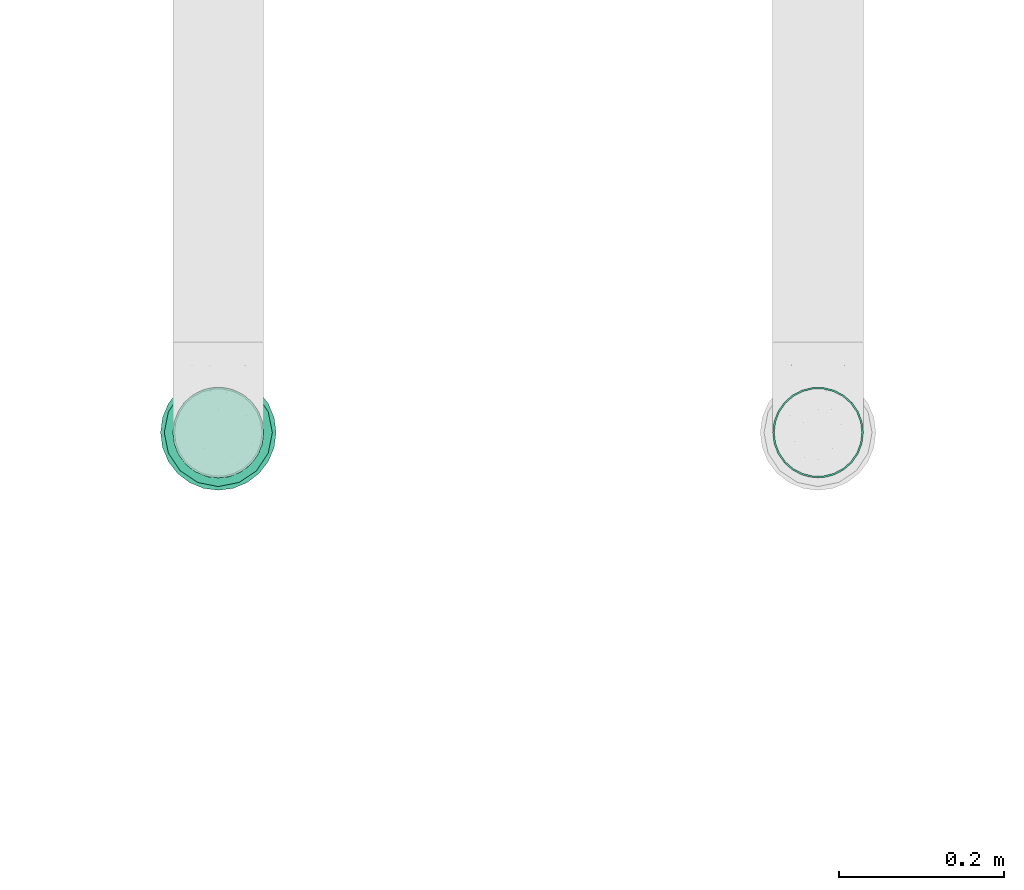
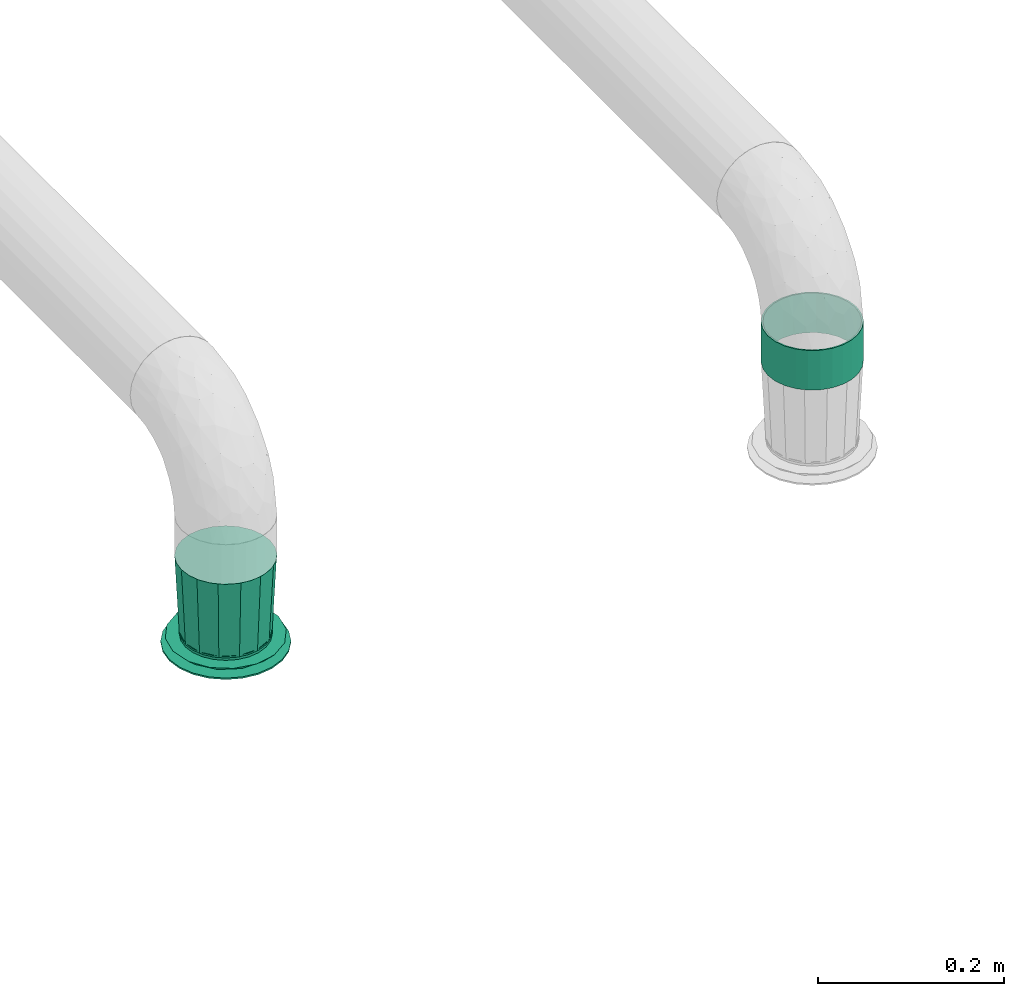
# One storey, part 93 of 115: 1 flow fitting, 1 flow segment, 1 flow terminal.
"""IFC2X3 building model written with IfcOpenShell, lengths in millimetres."""

from ifc_helpers import new_model, entity, si_unit, converted_unit, derived_unit, direction, frame, origin_with_axes, origin_2d_with_axis, place, context, subcontext, project, spatial, hollow_circle, extrude, open_shell, surface_model, source, transform, mapped, material, layer, layer_set, layer_usage, type_object, element, save


model = new_model("IFC2X3")

# Units and contexts
model_context = context("Model", 3, precision=1e-05, world=origin_with_axes(), true_north=direction((0.0, 1.0)))
body_context = subcontext(model_context, "Body", "Model", "MODEL_VIEW")
ifc_project = project(units=[si_unit("AREAUNIT", "SQUARE_METRE"), si_unit("VOLUMEUNIT", "CUBIC_METRE", prefix="DECI"), si_unit("TIMEUNIT", "SECOND"), si_unit("THERMODYNAMICTEMPERATUREUNIT", "DEGREE_CELSIUS"), si_unit("PRESSUREUNIT", "PASCAL"), si_unit("MASSUNIT", "GRAM", prefix="KILO"), si_unit("LENGTHUNIT", "METRE", prefix="MILLI"), si_unit("POWERUNIT", "WATT"), si_unit("ELECTRICCURRENTUNIT", "AMPERE"), si_unit("ELECTRICVOLTAGEUNIT", "VOLT"), derived_unit("VOLUMETRICFLOWRATEUNIT", [(si_unit("VOLUMEUNIT", "CUBIC_METRE", prefix="DECI"), 1), (si_unit("TIMEUNIT", "SECOND"), -1)]), derived_unit("LINEARVELOCITYUNIT", [(si_unit("LENGTHUNIT", "METRE"), 1), (si_unit("TIMEUNIT", "SECOND"), -1)]), derived_unit("MASSDENSITYUNIT", [(si_unit("MASSUNIT", "GRAM", prefix="KILO"), 1), (si_unit("VOLUMEUNIT", "CUBIC_METRE"), -1)]), converted_unit("PLANEANGLEUNIT", "DEGREE", entity("IfcRatioMeasure", 0.01745), si_unit("PLANEANGLEUNIT", "RADIAN"), dimensions=[0, 0, 0, 0, 0, 0, 0])], contexts=[model_context])

# Site, building, storey
site_placement = place(None, origin_with_axes())
site = spatial("IfcSite", under=ifc_project, at=site_placement, CompositionType="ELEMENT")
building_placement = place(site_placement, origin_with_axes())
building = spatial("IfcBuilding", under=site, at=building_placement, Name="mc-building", CompositionType="ELEMENT")
storey_placement = place(building_placement, frame((0.0, 0.0, 2950.0), z_axis=(0.0, 0.0, 1.0), x_axis=(1.0, 0.0, 0.0)))
storey = spatial("IfcBuildingStorey", under=building, at=storey_placement, Name="2. Korrus", CompositionType="ELEMENT", Elevation=2950.0)

# Flow terminal
air_terminal_type = type_object("IfcAirTerminalType", Name="100", PredefinedType="NOTDEFINED")
shared_shape_1 = source(origin_with_axes(), body_context, "Body", "SurfaceModel", [
    surface_model("IfcShellBasedSurfaceModel", [(11.2, 18.11733, -67.61481), (11.2, -18.11733, -67.61481), (11.2, 0.0, -70.0), (11.2, 67.61481, -18.11733), (11.2, 35.0, -60.62178), (11.2, 49.49747, -49.49747), (11.2, 60.62178, -35.0), (11.2, -67.61481, 18.11733), (11.2, -49.49747, -49.49747), (11.2, -67.61481, -18.11733), (11.2, -35.0, -60.62178), (11.2, -60.62178, -35.0), (11.2, -70.0, 0.0), (11.2, 18.11733, 67.61481), (11.2, 70.0, 0.0), (11.2, 67.61481, 18.11733), (11.2, 49.49747, 49.49747), (11.2, 60.62178, 35.0), (11.2, 35.0, 60.62178), (11.2, -49.49747, 49.49747), (11.2, -60.62178, 35.0), (11.2, -35.0, 60.62178), (11.2, -18.11733, 67.61481), (11.2, 0.0, 70.0), (9.2, 18.11733, 67.61481), (9.2, -67.61481, 18.11733), (9.2, 0.0, 70.0), (9.2, 49.49747, 49.49747), (9.2, 35.0, 60.62178), (9.2, 60.62178, 35.0), (9.2, 67.61481, 18.11733), (9.2, -35.0, 60.62178), (9.2, -49.49747, 49.49747), (9.2, -18.11733, 67.61481), (9.2, -60.62178, 35.0), (9.2, -67.61481, -18.11733), (9.2, -70.0, 0.0), (9.2, 67.61481, -18.11733), (9.2, 18.11733, -67.61481), (9.2, 49.49747, -49.49747), (9.2, 60.62178, -35.0), (9.2, 35.0, -60.62178), (9.2, -18.11733, -67.61481), (9.2, -49.49747, -49.49747), (9.2, -60.62178, -35.0), (9.2, -35.0, -60.62178), (9.2, 0.0, -70.0), (9.2, 70.0, 0.0), (9.2, 32.75, 0.0), (9.2, -16.375, 28.36233), (9.2, -28.36233, 16.375), (9.2, 16.375, 28.36233), (9.2, 0.0, 32.75), (9.2, 28.36233, 16.375), (9.2, -32.75, 0.0), (9.2, -16.375, -28.36233), (9.2, 16.375, -28.36233), (9.2, 0.0, -32.75), (9.2, 28.36233, -16.375), (9.2, -28.36233, -16.375), (6.2, -21.19625, -15.39997), (6.2, -21.19625, 15.39997), (6.2, 8.09625, 24.91768), (6.2, -8.09625, 24.91768), (6.2, -26.2, 0.0), (6.2, 21.19625, 15.39997), (6.2, -8.09625, -24.91768), (6.2, 21.19625, -15.39997), (6.2, 8.09625, -24.91768), (6.2, 26.2, 0.0), (9.2, 31.06579, -6.28555), (6.2, 23.69812, -7.69999), (6.2, -14.64625, -20.15883), (9.2, -22.36867, -22.36867), (6.2, -23.69812, -7.69999), (9.2, -31.06579, -6.28555), (6.2, 14.64625, -20.15883), (9.2, 8.1875, -30.55617), (6.2, 0.0, -24.91768), (9.2, 22.36867, -22.36867), (9.2, -8.1875, -30.55617), (9.2, -31.06579, 6.28555), (6.2, -23.69812, 7.69999), (6.2, 14.64625, 20.15883), (9.2, 22.36867, 22.36867), (6.2, 23.69812, 7.69999), (9.2, 31.06579, 6.28555), (6.2, -14.64625, 20.15883), (9.2, -8.1875, 30.55617), (6.2, 0.0, 24.91768), (9.2, -22.36867, 22.36867), (9.2, 8.1875, 30.55617), (6.2, -13.11761, 57.472), (6.2, -36.75472, 46.08897), (6.2, -53.11211, 25.57744), (6.2, 36.75472, 46.08897), (6.2, -58.95, 0.0), (6.2, 13.11761, 57.472), (6.2, 53.11211, 25.57744), (6.2, -53.11211, -25.57744), (6.2, -36.75472, -46.08897), (6.2, -13.11761, -57.472), (6.2, 58.95, 0.0), (6.2, 53.11211, -25.57744), (6.2, 13.11761, -57.472), (6.2, 36.75472, -46.08897), (0.0, -60.51411, 25.06576), (0.0, 0.0, 65.5), (0.0, 25.06576, 60.51411), (0.0, 46.3155, 46.3155), (0.0, 60.51411, 25.06576), (0.0, -46.3155, 46.3155), (0.0, -25.06576, 60.51411), (0.0, 0.0, -65.5), (0.0, -65.5, 0.0), (0.0, 65.5, 0.0), (0.0, 60.51411, -25.06576), (0.0, 46.3155, -46.3155), (0.0, 25.06576, -60.51411), (0.0, -46.3155, -46.3155), (0.0, -60.51411, -25.06576), (0.0, -25.06576, -60.51411), (6.2, 56.03105, -12.78872), (0.0, 53.4148, -35.69063), (0.0, 35.69063, -53.4148), (6.2, 24.93616, -51.78048), (0.0, -12.53288, -63.00706), (6.2, 0.0, -57.472), (0.0, -35.69063, -53.4148), (0.0, 63.00706, -12.53288), (6.2, 44.93342, -35.83321), (6.2, -24.93616, -51.78048), (6.2, -44.93342, -35.83321), (0.0, -53.4148, -35.69063), (0.0, 12.53288, -63.00706), (6.2, -56.03105, -12.78872), (0.0, -63.00706, -12.53288), (6.2, -56.03105, 12.78872), (0.0, -53.4148, 35.69063), (0.0, -35.69063, 53.4148), (6.2, -24.93616, 51.78048), (0.0, 12.53288, 63.00706), (6.2, 0.0, 57.472), (0.0, 35.69063, 53.4148), (0.0, -63.00706, 12.53288), (6.2, -44.93342, 35.83321), (6.2, 24.93616, 51.78048), (6.2, 44.93342, 35.83321), (0.0, 53.4148, 35.69063), (0.0, -12.53288, 63.00706), (6.2, 56.03105, 12.78872), (0.0, 63.00706, 12.53288), (-3.1, 12.94095, 48.29629), (-3.1, -35.35534, 35.35534), (-3.1, 0.0, 50.0), (-3.1, 35.35534, 35.35534), (-3.1, 25.0, 43.30127), (-3.1, -43.30127, 25.0), (-3.1, 43.30127, 25.0), (-3.1, -48.29629, -12.94095), (-3.1, -12.94095, 48.29629), (-3.1, -25.0, 43.30127), (-3.1, -50.0, 0.0), (-3.1, -48.29629, 12.94095), (-3.1, 48.29629, 12.94095), (-3.1, 12.94095, -48.29629), (-3.1, 50.0, 0.0), (-3.1, 48.29629, -12.94095), (-3.1, 35.35534, -35.35534), (-3.1, 43.30127, -25.0), (-3.1, 25.0, -43.30127), (-3.1, 0.0, -50.0), (-3.1, -35.35534, -35.35534), (-3.1, -43.30127, -25.0), (-3.1, -25.0, -43.30127), (-3.1, -12.94095, -48.29629), (0.0, 25.0, -43.30127), (0.0, 0.0, -50.0), (0.0, 12.94095, -48.29629), (0.0, 48.29629, -12.94095), (0.0, 35.35534, -35.35534), (0.0, -25.0, -43.30127), (0.0, 43.30127, -25.0), (0.0, -50.0, 0.0), (0.0, -12.94095, -48.29629), (0.0, -35.35534, -35.35534), (0.0, -48.29629, -12.94095), (0.0, -43.30127, -25.0), (0.0, 50.0, 0.0), (0.0, 43.30127, 25.0), (0.0, 12.94095, 48.29629), (0.0, 35.35534, 35.35534), (0.0, 25.0, 43.30127), (0.0, 0.0, 50.0), (0.0, -35.35534, 35.35534), (0.0, -43.30127, 25.0), (0.0, -48.29629, 12.94095), (0.0, -12.94095, 48.29629), (0.0, -25.0, 43.30127), (0.0, 48.29629, 12.94095), (-43.1, 0.0, 45.0), (-43.1, 11.64686, 43.46666), (-43.1, 22.5, 38.97115), (-43.1, -11.64686, 43.46666), (-43.1, 38.97115, 22.5), (-43.1, 43.46666, 11.64686), (-43.1, 31.81981, 31.81981), (-43.1, -22.5, 38.97115), (-43.1, -43.46666, 11.64686), (-43.1, -31.81981, 31.81981), (-43.1, -38.97115, 22.5), (-43.1, -45.0, 0.0), (-43.1, -43.46666, -11.64686), (-43.1, 45.0, 0.0), (-43.1, 43.46666, -11.64686), (-43.1, 38.97115, -22.5), (-43.1, 31.81981, -31.81981), (-43.1, 22.5, -38.97115), (-43.1, 11.64686, -43.46666), (-43.1, -31.81981, -31.81981), (-43.1, -38.97115, -22.5), (-43.1, -22.5, -38.97115), (-43.1, 0.0, -45.0), (-43.1, -11.64686, -43.46666), (-3.1, 22.5, -38.97115), (-3.1, 0.0, -45.0), (-3.1, 11.64686, -43.46666), (-3.1, 31.81981, -31.81981), (-3.1, -22.5, -38.97115), (-3.1, 38.97115, -22.5), (-3.1, 43.46666, -11.64686), (-3.1, 45.0, 0.0), (-3.1, -45.0, 0.0), (-3.1, -11.64686, -43.46666), (-3.1, -31.81981, -31.81981), (-3.1, -43.46666, -11.64686), (-3.1, -38.97115, -22.5), (-3.1, 0.0, 45.0), (-3.1, 43.46666, 11.64686), (-3.1, 38.97115, 22.5), (-3.1, 22.5, 38.97115), (-3.1, 31.81981, 31.81981), (-3.1, 11.64686, 43.46666), (-3.1, -11.64686, 43.46666), (-3.1, -43.46666, 11.64686), (-3.1, -31.81981, 31.81981), (-3.1, -38.97115, 22.5), (-3.1, -22.5, 38.97115)], [open_shell([[[0, 1, 2]], [[3, 0, 4]], [[5, 6, 3]], [[5, 3, 4]], [[7, 1, 0]], [[8, 7, 9]], [[10, 7, 8]], [[8, 9, 11]], [[12, 9, 7]], [[1, 7, 10]], [[7, 0, 3]], [[13, 14, 15]], [[16, 15, 17]], [[16, 18, 13]], [[16, 13, 15]], [[14, 13, 7]], [[7, 19, 20]], [[19, 7, 21]], [[7, 22, 21]], [[22, 7, 23]], [[7, 13, 23]], [[14, 7, 3]], [[24, 25, 26]], [[27, 24, 28]], [[27, 29, 30]], [[27, 30, 24]], [[25, 24, 30]], [[31, 25, 32]], [[25, 31, 33]], [[32, 25, 34]], [[33, 26, 25]], [[25, 35, 36]], [[25, 30, 37]], [[25, 37, 38]], [[39, 37, 40]], [[39, 41, 38]], [[39, 38, 37]], [[38, 42, 25]], [[35, 43, 44]], [[35, 25, 43]], [[45, 43, 25]], [[42, 45, 25]], [[38, 46, 42]], [[37, 30, 47]], [[35, 9, 36]], [[44, 11, 35]], [[10, 43, 45]], [[44, 43, 8]], [[1, 45, 42]], [[35, 11, 9]], [[9, 12, 36]], [[1, 10, 45]], [[8, 43, 10]], [[8, 11, 44]], [[2, 1, 42]], [[42, 46, 2]], [[38, 0, 46]], [[41, 4, 38]], [[6, 39, 40]], [[41, 39, 5]], [[3, 40, 37]], [[41, 5, 4]], [[4, 0, 38]], [[14, 3, 37]], [[6, 40, 3]], [[6, 5, 39]], [[47, 14, 37]], [[46, 0, 2]], [[30, 15, 47]], [[29, 17, 30]], [[18, 27, 28]], [[29, 27, 16]], [[13, 28, 24]], [[30, 17, 15]], [[15, 14, 47]], [[13, 18, 28]], [[16, 27, 18]], [[16, 17, 29]], [[23, 13, 24]], [[24, 26, 23]], [[33, 22, 26]], [[31, 21, 33]], [[20, 32, 34]], [[31, 32, 19]], [[7, 34, 25]], [[31, 19, 21]], [[21, 22, 33]], [[12, 7, 25]], [[20, 34, 7]], [[20, 19, 32]], [[36, 12, 25]], [[26, 22, 23]], [[48, 49, 50]], [[48, 51, 49]], [[49, 51, 52]], [[53, 51, 48]], [[48, 50, 54]], [[54, 55, 48]], [[56, 55, 57]], [[55, 58, 48]], [[58, 55, 56]], [[55, 54, 59]], [[60, 61, 62]], [[62, 61, 63]], [[64, 61, 60]], [[62, 65, 66]], [[67, 68, 65]], [[66, 60, 62]], [[65, 68, 66]], [[69, 67, 65]], [[69, 48, 70]], [[58, 71, 70]], [[72, 73, 60]], [[59, 74, 60]], [[75, 64, 74]], [[56, 68, 76]], [[72, 66, 55]], [[73, 72, 55]], [[68, 77, 78]], [[64, 75, 54]], [[59, 75, 74]], [[70, 71, 69]], [[67, 79, 76]], [[80, 55, 66]], [[68, 56, 77]], [[56, 76, 79]], [[79, 67, 58]], [[71, 58, 67]], [[80, 78, 57]], [[77, 57, 78]], [[66, 78, 80]], [[59, 60, 73]], [[64, 54, 81]], [[50, 82, 81]], [[83, 84, 65]], [[53, 85, 65]], [[86, 69, 85]], [[49, 63, 87]], [[83, 62, 51]], [[84, 83, 51]], [[63, 88, 89]], [[69, 86, 48]], [[53, 86, 85]], [[81, 82, 64]], [[61, 90, 87]], [[91, 51, 62]], [[63, 49, 88]], [[49, 87, 90]], [[90, 61, 50]], [[82, 50, 61]], [[91, 89, 52]], [[88, 52, 89]], [[62, 89, 91]], [[53, 65, 84]], [[92, 93, 94]], [[95, 94, 96]], [[97, 92, 95]], [[95, 92, 94]], [[96, 98, 95]], [[96, 99, 98]], [[99, 100, 101]], [[101, 102, 98]], [[102, 101, 103]], [[104, 105, 103]], [[101, 104, 103]], [[101, 98, 99]], [[106, 107, 108]], [[109, 110, 108]], [[106, 108, 110]], [[111, 112, 106]], [[106, 112, 107]], [[106, 113, 114]], [[106, 110, 113]], [[115, 116, 117]], [[117, 113, 110]], [[113, 117, 118]], [[114, 119, 120]], [[121, 119, 114]], [[121, 114, 113]], [[115, 117, 110]], [[103, 116, 122]], [[123, 116, 103]], [[124, 125, 118]], [[101, 126, 127]], [[100, 119, 128]], [[102, 122, 129]], [[103, 130, 123]], [[102, 129, 115]], [[113, 127, 126]], [[125, 124, 105]], [[130, 105, 117]], [[118, 125, 104]], [[124, 117, 105]], [[131, 100, 128]], [[119, 100, 132]], [[133, 99, 120]], [[134, 118, 104]], [[122, 116, 129]], [[127, 134, 104]], [[131, 121, 101]], [[99, 133, 132]], [[128, 121, 131]], [[130, 117, 123]], [[101, 121, 126]], [[99, 135, 120]], [[96, 136, 135]], [[136, 120, 135]], [[134, 127, 113]], [[133, 119, 132]], [[136, 96, 114]], [[94, 106, 137]], [[138, 106, 94]], [[139, 140, 112]], [[97, 141, 142]], [[95, 109, 143]], [[96, 137, 144]], [[94, 145, 138]], [[96, 144, 114]], [[107, 142, 141]], [[140, 139, 93]], [[145, 93, 111]], [[112, 140, 92]], [[139, 111, 93]], [[146, 95, 143]], [[109, 95, 147]], [[148, 98, 110]], [[149, 112, 92]], [[137, 106, 144]], [[142, 149, 92]], [[146, 108, 97]], [[98, 148, 147]], [[143, 108, 146]], [[145, 111, 138]], [[97, 108, 141]], [[98, 150, 110]], [[102, 151, 150]], [[151, 110, 150]], [[149, 142, 107]], [[148, 109, 147]], [[151, 102, 115]], [[152, 153, 154]], [[155, 152, 156]], [[157, 152, 158]], [[158, 152, 155]], [[158, 159, 157]], [[160, 153, 161]], [[160, 154, 153]], [[157, 162, 163]], [[153, 152, 157]], [[157, 159, 162]], [[158, 164, 159]], [[165, 166, 167]], [[168, 167, 169]], [[170, 165, 167]], [[170, 167, 168]], [[166, 165, 171]], [[159, 172, 173]], [[172, 159, 174]], [[174, 171, 175]], [[159, 164, 174]], [[166, 171, 174]], [[174, 164, 166]], [[176, 177, 178]], [[179, 176, 180]], [[176, 179, 181]], [[179, 180, 182]], [[179, 183, 181]], [[177, 181, 184]], [[177, 176, 181]], [[185, 186, 187]], [[186, 185, 181]], [[181, 183, 186]], [[183, 179, 188]], [[183, 188, 189]], [[190, 189, 191]], [[189, 190, 183]], [[190, 191, 192]], [[193, 194, 190]], [[183, 195, 196]], [[183, 190, 195]], [[194, 197, 198]], [[194, 195, 190]], [[197, 194, 193]], [[189, 188, 199]], [[164, 199, 166]], [[158, 189, 164]], [[192, 155, 156]], [[158, 155, 191]], [[190, 156, 152]], [[164, 189, 199]], [[199, 188, 166]], [[190, 192, 156]], [[191, 155, 192]], [[191, 189, 158]], [[193, 190, 152]], [[152, 154, 193]], [[160, 197, 154]], [[161, 198, 160]], [[195, 153, 157]], [[161, 153, 194]], [[196, 157, 163]], [[161, 194, 198]], [[198, 197, 160]], [[183, 196, 163]], [[195, 157, 196]], [[195, 194, 153]], [[162, 183, 163]], [[154, 197, 193]], [[159, 186, 162]], [[173, 187, 159]], [[181, 172, 174]], [[173, 172, 185]], [[184, 174, 175]], [[159, 187, 186]], [[186, 183, 162]], [[184, 181, 174]], [[185, 172, 181]], [[185, 187, 173]], [[177, 184, 175]], [[175, 171, 177]], [[165, 178, 171]], [[170, 176, 165]], [[182, 168, 169]], [[170, 168, 180]], [[179, 169, 167]], [[170, 180, 176]], [[176, 178, 165]], [[188, 179, 167]], [[182, 169, 179]], [[182, 180, 168]], [[166, 188, 167]], [[171, 178, 177]], [[200, 201, 202]], [[203, 200, 202]], [[204, 205, 202]], [[204, 202, 206]], [[203, 202, 205]], [[207, 208, 209]], [[207, 203, 205]], [[209, 208, 210]], [[211, 208, 212]], [[208, 207, 212]], [[207, 205, 212]], [[213, 214, 215]], [[205, 215, 212]], [[212, 216, 217]], [[216, 212, 215]], [[218, 219, 217]], [[212, 219, 220]], [[212, 217, 219]], [[221, 222, 223]], [[222, 221, 219]], [[218, 222, 219]], [[215, 205, 213]], [[224, 225, 226]], [[227, 228, 224]], [[229, 230, 231]], [[228, 227, 229]], [[229, 232, 228]], [[225, 228, 233]], [[225, 224, 228]], [[234, 235, 236]], [[235, 234, 228]], [[228, 232, 235]], [[232, 229, 231]], [[237, 238, 239]], [[240, 239, 241]], [[240, 242, 237]], [[240, 237, 239]], [[238, 237, 243]], [[244, 245, 246]], [[247, 244, 232]], [[244, 247, 245]], [[232, 238, 247]], [[238, 243, 247]], [[238, 232, 231]], [[205, 238, 213]], [[204, 239, 205]], [[240, 206, 202]], [[204, 206, 241]], [[242, 202, 201]], [[205, 239, 238]], [[238, 231, 213]], [[240, 202, 242]], [[241, 206, 240]], [[241, 239, 204]], [[201, 237, 242]], [[201, 200, 237]], [[243, 203, 207]], [[209, 247, 207]], [[246, 210, 208]], [[209, 210, 245]], [[244, 208, 211]], [[203, 243, 200]], [[207, 247, 243]], [[200, 243, 237]], [[209, 245, 247]], [[210, 246, 245]], [[244, 246, 208]], [[211, 232, 244]], [[212, 235, 211]], [[220, 236, 212]], [[228, 219, 221]], [[220, 219, 234]], [[233, 221, 223]], [[212, 236, 235]], [[235, 232, 211]], [[233, 228, 221]], [[234, 219, 228]], [[234, 236, 220]], [[225, 233, 223]], [[223, 222, 225]], [[226, 218, 217]], [[216, 224, 217]], [[229, 215, 214]], [[216, 215, 227]], [[230, 214, 213]], [[218, 226, 222]], [[217, 224, 226]], [[222, 226, 225]], [[216, 227, 224]], [[215, 229, 227]], [[230, 229, 214]], [[213, 231, 230]]])]),
])
flow_terminal_placement = place(storey_placement, frame((33284.80157, 8183.57591, 2200.0), z_axis=(0.0, 1.0, 0.0), x_axis=(0.0, 0.0, -1.0)))
element("IfcFlowTerminal", 1, at=flow_terminal_placement, inside=storey, type_object=air_terminal_type, Name="100", context=body_context, shape_type="MappedRepresentation", body=[
    mapped(shared_shape_1, transform((0.0, 0.0, 0.0), scale=1.0)),
])

# Flow segment
ifc_material = material(Name="FZ1")
ifc_layer = layer(ifc_material, 0.0)
ifc_layer_set = layer_set([ifc_layer], Name="FZ1")
ifc_layer_usage = layer_usage(ifc_layer_set, "AXIS1", "POSITIVE", 0.0)
duct_segment_type = type_object("IfcDuctSegmentType", PredefinedType="RIGIDSEGMENT")
shared_shape_2 = source(origin_with_axes(), body_context, "Body", "SweptSolid", [
    extrude(hollow_circle(Radius=55.0, WallThickness=2.0, at=origin_2d_with_axis()), frame((0.0, 0.0, 0.0), z_axis=(1.0, 0.0, 0.0), x_axis=(0.0, 1.0, 0.0)), (0.0, 0.0, 1.0), 51.9),
])
flow_segment_placement = place(storey_placement, frame((34011.69824, 8183.57591, 2355.0), z_axis=(0.0, 1.0, 0.0), x_axis=(0.0, 0.0, -1.0)))
element("IfcFlowSegment", 2, at=flow_segment_placement, inside=storey, type_object=duct_segment_type, material=ifc_layer_usage, context=body_context, shape_type="MappedRepresentation", body=[
    mapped(shared_shape_2, transform((0.0, 0.0, 0.0), scale=1.0)),
])

# Flow fitting
duct_fitting_type = type_object("IfcDuctFittingType", PredefinedType="TRANSITION")
shared_shape_3 = source(origin_with_axes(), body_context, "Body", "SurfaceModel", [
    surface_model("IfcShellBasedSurfaceModel", [(0.0, 12.94095, 48.29629), (0.0, -35.35534, 35.35534), (0.0, 0.0, 50.0), (0.0, 35.35534, 35.35534), (0.0, 25.0, 43.30127), (0.0, 43.30127, 25.0), (0.0, 48.29629, 12.94095), (0.0, -12.94095, 48.29629), (0.0, -25.0, 43.30127), (0.0, -48.29629, 12.94095), (0.0, -43.30127, 25.0), (0.0, -25.0, -43.30127), (0.0, -48.29629, -12.94095), (0.0, -50.0, 0.0), (0.0, 48.29629, -12.94095), (0.0, 12.94095, -48.29629), (0.0, 43.30127, -25.0), (0.0, 35.35534, -35.35534), (0.0, 25.0, -43.30127), (0.0, -35.35534, -35.35534), (0.0, -43.30127, -25.0), (0.0, -12.94095, -48.29629), (0.0, 0.0, -50.0), (0.0, 50.0, 0.0), (100.0, -55.0, 0.0), (100.0, -12.23865, 53.62104), (100.0, -34.29194, 43.00073), (100.0, 49.55329, -23.86361), (100.0, 12.23865, 53.62104), (100.0, 34.29194, 43.00073), (100.0, 55.0, 0.0), (100.0, 49.55329, 23.86361), (100.0, -49.55329, 23.86361), (100.0, 12.23865, -53.62104), (100.0, -49.55329, -23.86361), (100.0, -34.29194, -43.00073), (100.0, 34.29194, -43.00073), (100.0, -12.23865, -53.62104), (0.0, 11.12605, 48.7464), (0.0, -11.12605, 48.7464), (0.0, 31.17449, 39.09157), (0.0, -45.04844, -21.69419), (0.0, -45.04844, 21.69419), (0.0, -31.17449, 39.09157), (0.0, 45.04844, 21.69419), (0.0, 45.04844, -21.69419), (0.0, 31.17449, -39.09157), (0.0, -31.17449, -39.09157), (0.0, -11.12605, -48.7464), (0.0, 11.12605, -48.7464), (0.0, -47.52422, -10.84709), (100.0, -41.92261, -33.43217), (0.0, -38.11147, -30.39288), (100.0, 41.92261, -33.43217), (0.0, 38.11147, -30.39288), (0.0, -21.15027, -43.91899), (100.0, -23.2653, -48.31088), (100.0, -52.32388, -11.72483), (100.0, 0.0, -53.62104), (0.0, 0.0, -48.7464), (100.0, 23.2653, -48.31088), (0.0, 21.15027, -43.91899), (100.0, 52.32388, -11.72483), (0.0, 47.52422, -10.84709), (0.0, 47.52422, 10.84709), (100.0, 41.92261, 33.43217), (0.0, 38.11147, 30.39288), (100.0, -41.92261, 33.43217), (0.0, -38.11147, 30.39288), (0.0, 21.15027, 43.91899), (100.0, 23.2653, 48.31088), (100.0, 52.32388, 11.72483), (100.0, 0.0, 53.62104), (0.0, 0.0, 48.7464), (100.0, -23.2653, 48.31088), (0.0, -21.15027, 43.91899), (100.0, -52.32388, 11.72483), (0.0, -47.52422, 10.84709), (100.0, 27.5, -47.63139), (100.0, 0.0, -55.0), (100.0, 14.23505, -53.12592), (100.0, 38.89087, -38.89087), (100.0, -27.5, -47.63139), (100.0, 47.63139, -27.5), (100.0, 53.12592, -14.23505), (100.0, -14.23505, -53.12592), (100.0, -47.63139, -27.5), (100.0, -38.89087, -38.89087), (100.0, -53.12592, -14.23505), (100.0, 53.12592, 14.23505), (100.0, 47.63139, 27.5), (100.0, 27.5, 47.63139), (100.0, 38.89087, 38.89087), (100.0, 14.23505, 53.12592), (100.0, 0.0, 55.0), (100.0, -47.63139, 27.5), (100.0, -53.12592, 14.23505), (100.0, -27.5, 47.63139), (100.0, -38.89087, 38.89087), (100.0, -14.23505, 53.12592), (98.0, 0.0, 55.0), (98.0, 14.23505, 53.12592), (98.0, 27.5, 47.63139), (98.0, 38.89087, 38.89087), (98.0, 47.63139, 27.5), (98.0, -47.63139, 27.5), (98.0, 53.12592, -14.23505), (98.0, -27.5, 47.63139), (98.0, -14.23505, 53.12592), (98.0, -38.89087, 38.89087), (98.0, -55.0, 0.0), (98.0, -53.12592, 14.23505), (98.0, 53.12592, 14.23505), (98.0, 47.63139, -27.5), (98.0, -27.5, -47.63139), (98.0, 0.0, -55.0), (98.0, 38.89087, -38.89087), (98.0, 27.5, -47.63139), (98.0, 14.23505, -53.12592), (98.0, -47.63139, -27.5), (98.0, -38.89087, -38.89087), (98.0, -53.12592, -14.23505), (98.0, -14.23505, -53.12592), (98.0, 55.0, 0.0), (2.0, 12.94095, -48.29629), (2.0, 25.0, -43.30127), (2.0, 35.35534, -35.35534), (2.0, 43.30127, -25.0), (2.0, 48.29629, -12.94095), (2.0, 0.0, -50.0), (2.0, 50.0, 0.0), (2.0, -25.0, -43.30127), (2.0, -12.94095, -48.29629), (2.0, -35.35534, -35.35534), (2.0, -48.29629, -12.94095), (2.0, -43.30127, -25.0), (2.0, -48.29629, 12.94095), (2.0, 48.29629, 12.94095), (2.0, 43.30127, 25.0), (2.0, 35.35534, 35.35534), (2.0, -35.35534, 35.35534), (2.0, 12.94095, 48.29629), (2.0, 25.0, 43.30127), (2.0, 0.0, 50.0), (2.0, -43.30127, 25.0), (2.0, -50.0, 0.0), (2.0, -12.94095, 48.29629), (2.0, -25.0, 43.30127)], [open_shell([[[0, 1, 2]], [[3, 0, 4]], [[3, 5, 6]], [[0, 3, 1]], [[6, 1, 3]], [[7, 1, 8]], [[7, 2, 1]], [[1, 9, 10]], [[9, 1, 11]], [[12, 13, 9]], [[11, 1, 6]], [[6, 14, 11]], [[15, 14, 16]], [[17, 18, 15]], [[17, 15, 16]], [[11, 14, 15]], [[12, 19, 20]], [[19, 12, 11]], [[15, 21, 11]], [[12, 9, 11]], [[22, 21, 15]], [[14, 6, 23]], [[24, 25, 26]], [[25, 27, 28]], [[29, 28, 27]], [[27, 30, 31]], [[31, 29, 27]], [[24, 26, 32]], [[33, 24, 34]], [[33, 34, 35]], [[36, 27, 33]], [[33, 27, 24]], [[35, 37, 33]], [[24, 27, 25]], [[38, 23, 39]], [[40, 23, 38]], [[41, 42, 43]], [[41, 13, 42]], [[23, 43, 39]], [[40, 44, 23]], [[41, 23, 45]], [[41, 45, 46]], [[47, 41, 48]], [[49, 48, 41]], [[41, 46, 49]], [[23, 41, 43]], [[34, 50, 41]], [[47, 51, 52]], [[45, 27, 53]], [[36, 54, 53]], [[55, 48, 56]], [[34, 57, 50]], [[57, 13, 50]], [[13, 57, 24]], [[55, 35, 47]], [[35, 51, 47]], [[51, 41, 52]], [[58, 59, 49]], [[60, 61, 46]], [[37, 59, 58]], [[62, 63, 23]], [[35, 55, 56]], [[23, 30, 62]], [[53, 54, 45]], [[48, 37, 56]], [[33, 49, 61]], [[49, 33, 58]], [[54, 36, 46]], [[63, 27, 45]], [[34, 41, 51]], [[33, 61, 60]], [[48, 59, 37]], [[27, 63, 62]], [[46, 36, 60]], [[31, 64, 44]], [[40, 65, 66]], [[42, 32, 67]], [[26, 68, 67]], [[69, 38, 70]], [[31, 71, 64]], [[71, 23, 64]], [[23, 71, 30]], [[69, 29, 40]], [[29, 65, 40]], [[65, 44, 66]], [[72, 73, 39]], [[74, 75, 43]], [[28, 73, 72]], [[76, 77, 13]], [[29, 69, 70]], [[13, 24, 76]], [[67, 68, 42]], [[38, 28, 70]], [[25, 39, 75]], [[39, 25, 72]], [[68, 26, 43]], [[77, 32, 42]], [[31, 44, 65]], [[25, 75, 74]], [[38, 73, 28]], [[32, 77, 76]], [[43, 26, 74]], [[78, 79, 80]], [[81, 82, 78]], [[82, 83, 84]], [[81, 83, 82]], [[30, 82, 84]], [[79, 82, 85]], [[79, 78, 82]], [[82, 86, 87]], [[82, 30, 86]], [[24, 88, 86]], [[86, 30, 89]], [[90, 24, 89]], [[91, 90, 92]], [[91, 93, 94]], [[90, 91, 24]], [[94, 95, 91]], [[24, 95, 96]], [[24, 91, 95]], [[94, 97, 98]], [[98, 95, 94]], [[97, 94, 99]], [[89, 24, 86]], [[100, 101, 102]], [[100, 102, 103]], [[100, 104, 105]], [[104, 100, 103]], [[106, 105, 104]], [[100, 107, 108]], [[100, 109, 107]], [[105, 110, 111]], [[109, 100, 105]], [[105, 106, 110]], [[106, 104, 112]], [[106, 113, 110]], [[113, 114, 110]], [[115, 116, 117]], [[113, 116, 115]], [[117, 118, 115]], [[119, 114, 120]], [[121, 110, 119]], [[114, 115, 122]], [[119, 110, 114]], [[115, 114, 113]], [[123, 106, 112]], [[121, 88, 110]], [[119, 86, 121]], [[82, 120, 114]], [[119, 120, 87]], [[85, 114, 122]], [[121, 86, 88]], [[88, 24, 110]], [[85, 82, 114]], [[87, 120, 82]], [[87, 86, 119]], [[79, 85, 122]], [[122, 115, 79]], [[118, 80, 115]], [[117, 78, 118]], [[83, 116, 113]], [[117, 116, 81]], [[84, 113, 106]], [[117, 81, 78]], [[78, 80, 118]], [[30, 84, 106]], [[83, 113, 84]], [[83, 81, 116]], [[123, 30, 106]], [[115, 80, 79]], [[112, 89, 123]], [[104, 90, 112]], [[91, 103, 102]], [[104, 103, 92]], [[93, 102, 101]], [[112, 90, 89]], [[89, 30, 123]], [[93, 91, 102]], [[92, 103, 91]], [[92, 90, 104]], [[94, 93, 101]], [[101, 100, 94]], [[108, 99, 100]], [[107, 97, 108]], [[95, 109, 105]], [[107, 109, 98]], [[96, 105, 111]], [[107, 98, 97]], [[97, 99, 108]], [[24, 96, 111]], [[95, 105, 96]], [[95, 98, 109]], [[110, 24, 111]], [[100, 99, 94]], [[124, 125, 126]], [[124, 126, 127]], [[124, 128, 129]], [[128, 124, 127]], [[129, 128, 130]], [[129, 131, 132]], [[129, 130, 131]], [[133, 134, 135]], [[134, 133, 131]], [[131, 136, 134]], [[131, 130, 137]], [[137, 138, 139]], [[140, 137, 139]], [[140, 139, 141]], [[141, 139, 142]], [[140, 141, 143]], [[136, 140, 144]], [[145, 134, 136]], [[140, 146, 147]], [[131, 140, 136]], [[143, 146, 140]], [[131, 137, 140]], [[12, 134, 13]], [[20, 135, 12]], [[131, 19, 11]], [[20, 19, 133]], [[132, 11, 21]], [[12, 135, 134]], [[134, 145, 13]], [[132, 131, 11]], [[133, 19, 131]], [[133, 135, 20]], [[129, 132, 21]], [[21, 22, 129]], [[15, 124, 22]], [[18, 125, 15]], [[127, 17, 16]], [[18, 17, 126]], [[128, 16, 14]], [[18, 126, 125]], [[125, 124, 15]], [[130, 128, 14]], [[127, 16, 128]], [[127, 126, 17]], [[23, 130, 14]], [[22, 124, 129]], [[6, 137, 23]], [[5, 138, 6]], [[142, 3, 4]], [[5, 3, 139]], [[141, 4, 0]], [[6, 138, 137]], [[137, 130, 23]], [[141, 142, 4]], [[139, 3, 142]], [[139, 138, 5]], [[143, 141, 0]], [[0, 2, 143]], [[7, 146, 2]], [[8, 147, 7]], [[144, 1, 10]], [[8, 1, 140]], [[136, 10, 9]], [[8, 140, 147]], [[147, 146, 7]], [[145, 136, 9]], [[144, 10, 136]], [[144, 140, 1]], [[13, 145, 9]], [[2, 146, 143]]])]),
])
flow_fitting_placement = place(storey_placement, frame((33284.80157, 8183.57591, 2203.1), z_axis=(0.0, 1.0, 0.0), x_axis=(0.0, 0.0, 1.0)))
element("IfcFlowFitting", 3, at=flow_fitting_placement, inside=storey, type_object=duct_fitting_type, context=body_context, shape_type="MappedRepresentation", body=[
    mapped(shared_shape_3, transform((0.0, 0.0, 0.0), scale=1.0)),
])

save(model, "model.ifc")
